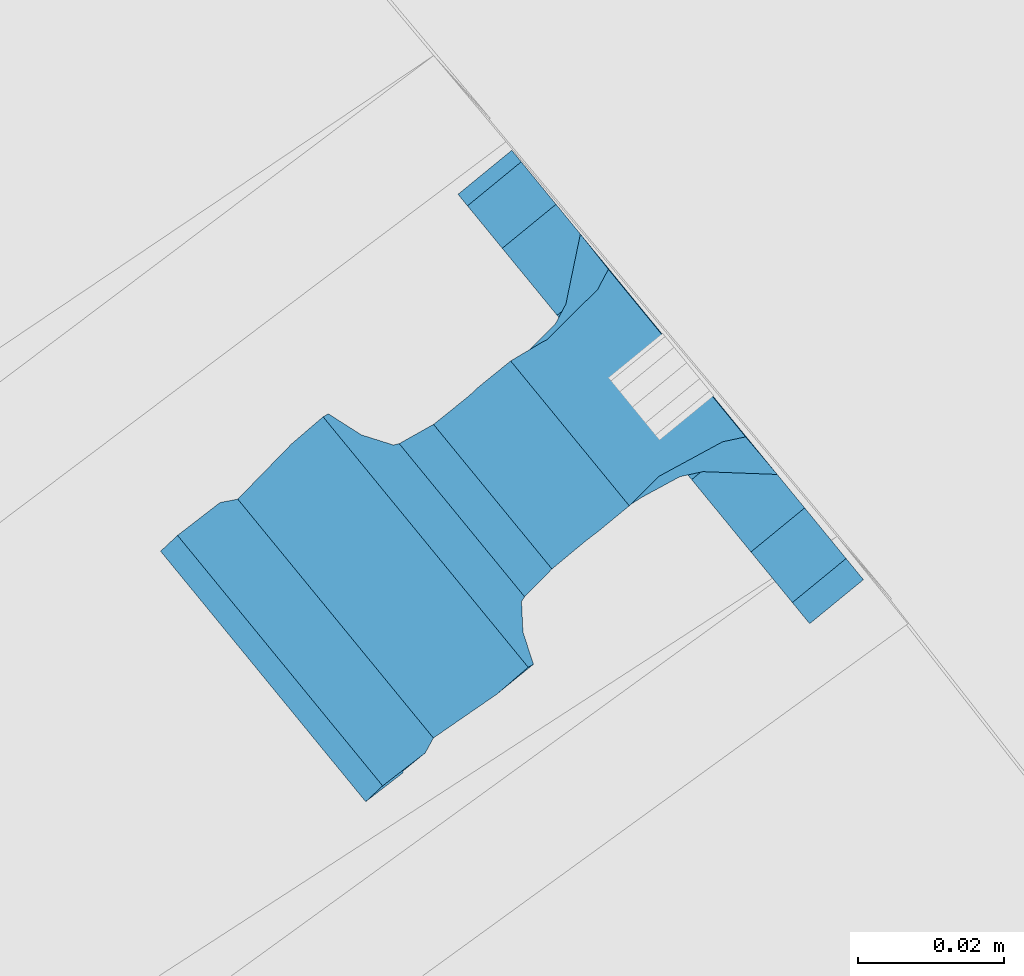
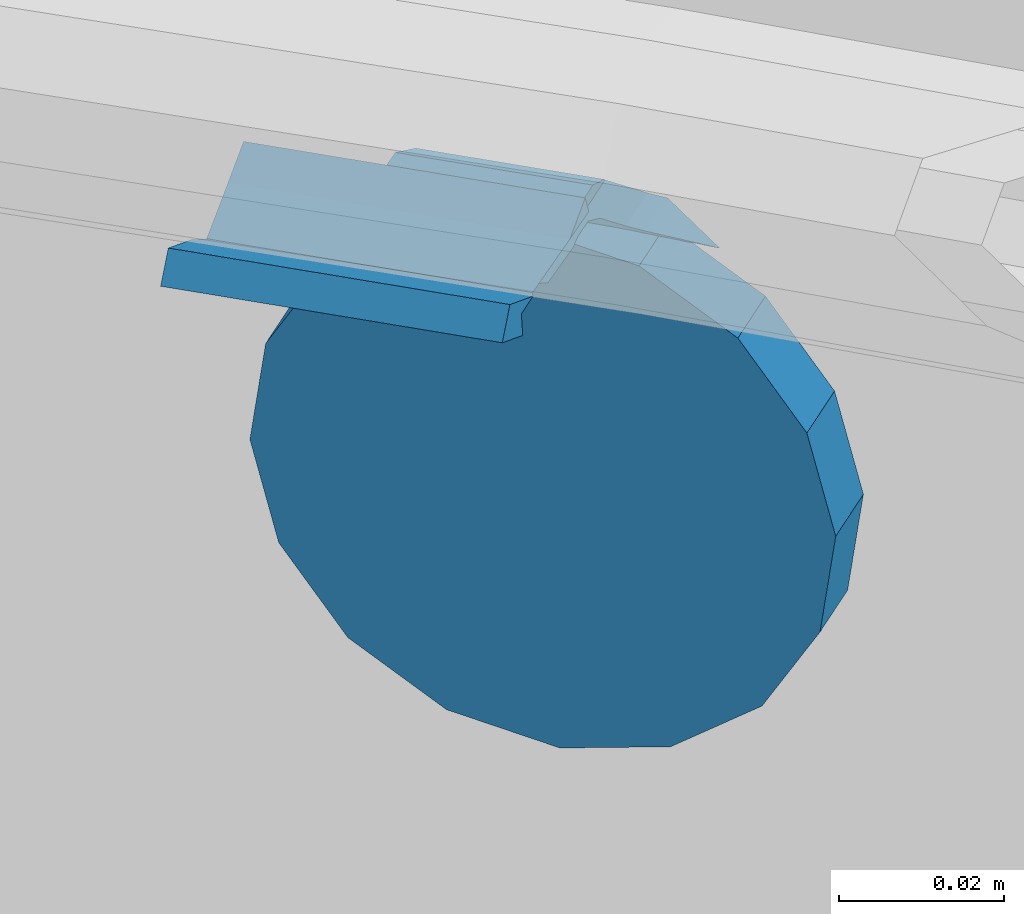
# One storey, part 524 of 975: 1 beam.
"""IFC2X3 building model written with IfcOpenShell, lengths in millimetres."""

import ifcopenshell
import ifcopenshell.guid

model = None  # the IFC model being written
_history = None  # IfcOwnerHistory: only IFC2X3 demands one
_inside = {}  # id of a spatial element -> (the spatial element, [elements in it])
_under = {}  # id of a project, library or spatial element -> (it, [spatial elements below it])
_declared = {}  # id of a project -> (the project, [libraries it declares])
_typed = {}  # id of a type object -> (the type object, [elements of that type])
_made_of = {}  # id of a material, layer set ... -> (it, [elements and type objects made of it])


def new_model(schema):
    """Start an empty IFC model of exactly this schema.

    Asked for "IFC4X3", IfcOpenShell would pick the latest addendum, in which some entities
    have other attributes; the version numbers below select the first issue.
    IFC2X3 requires an IfcOwnerHistory on every rooted entity: one is made here for all.
    """
    global model, _history
    if schema == "IFC4X3":
        model = ifcopenshell.file(schema_version=(4, 3, 0, 0))
    else:
        model = ifcopenshell.file(schema=schema)
    _inside.clear()
    _under.clear()
    _declared.clear()
    _typed.clear()
    _made_of.clear()
    _history = None
    if model.schema == "IFC2X3":
        org = make("IfcOrganization", Name="unknown")
        user = make(
            "IfcPersonAndOrganization",
            ThePerson=make("IfcPerson", FamilyName="unknown"),
            TheOrganization=org,
        )
        app = make(
            "IfcApplication",
            ApplicationDeveloper=org,
            Version="unknown",
            ApplicationFullName="unknown",
            ApplicationIdentifier="unknown",
        )
        _history = make(
            "IfcOwnerHistory",
            OwningUser=user,
            OwningApplication=app,
            ChangeAction="ADDED",
            CreationDate=0,
        )
    return model


def make(cls, **values):
    """One entity of the class cls with the attributes given. An attribute that is None is left unset."""
    return model.create_entity(
        cls, **{name: value for name, value in values.items() if value is not None}
    )


def rooted(cls, **values):
    """An entity with a GlobalId (a new one), such as an element, a storey or a relation."""
    return make(cls, GlobalId=ifcopenshell.guid.new(), OwnerHistory=_history, **values)


def si_unit(unit_type, name, prefix=None):
    """IfcSIUnit, for example si_unit("LENGTHUNIT", "METRE", prefix="MILLI")."""
    return make("IfcSIUnit", UnitType=unit_type, Prefix=prefix, Name=name)


def assignment(units):
    """IfcUnitAssignment: the units of a project."""
    return None if units is None else make("IfcUnitAssignment", Units=units)


def point(xyz):
    """IfcCartesianPoint."""
    return None if xyz is None else make("IfcCartesianPoint", Coordinates=xyz)


def direction(xyz):
    """IfcDirection."""
    return None if xyz is None else make("IfcDirection", DirectionRatios=xyz)


def frame(location, z_axis=None, x_axis=None):
    """IfcAxis2Placement3D, a coordinate frame: its origin and axes. An axis left out is left unset."""
    return make(
        "IfcAxis2Placement3D",
        Location=point(location),
        Axis=direction(z_axis),
        RefDirection=direction(x_axis),
    )


def origin_with_axes():
    """The frame at (0, 0, 0) with the z axis (0, 0, 1) and the x axis (1, 0, 0) written out."""
    return frame((0.0, 0.0, 0.0), z_axis=(0.0, 0.0, 1.0), x_axis=(1.0, 0.0, 0.0))


def place(relative_to, where):
    """IfcLocalPlacement: puts the frame where relative to a parent placement (None: the world)."""
    return make(
        "IfcLocalPlacement", PlacementRelTo=relative_to, RelativePlacement=where
    )


def context(
    kind, dimensions, precision=None, world=None, true_north=None, identifier=None
):
    """IfcGeometricRepresentationContext, for example the 3D "Model" context."""
    return make(
        "IfcGeometricRepresentationContext",
        ContextIdentifier=identifier,
        ContextType=kind,
        CoordinateSpaceDimension=dimensions,
        Precision=precision,
        WorldCoordinateSystem=world,
        TrueNorth=true_north,
    )


def subcontext(parent, identifier, kind, view, scale=None):
    """IfcGeometricRepresentationSubContext, for example "Body" below "Model"."""
    return make(
        "IfcGeometricRepresentationSubContext",
        ContextIdentifier=identifier,
        ContextType=kind,
        ParentContext=parent,
        TargetScale=scale,
        TargetView=view,
    )


def project(units=None, contexts=None):
    """IfcProject with its units and contexts."""
    return rooted(
        "IfcProject",
        Name="project",
        RepresentationContexts=contexts,
        UnitsInContext=assignment(units),
    )


def spatial(cls, under=None, at=None, **own):
    """A site, building, storey or space (cls), placed at a placement, below another one or the project."""
    s = rooted(cls, ObjectPlacement=at, **own)
    if under is not None:
        _under.setdefault(under.id(), (under, []))[1].append(s)
    return s


def faces_of(points, faces, orient=None, outer=None):
    """IfcFace entities. A face is a list of loops; a loop is a list of indices into points, from 0.

    orient and outer hold one flag for each loop. By default every Orientation is true, the
    first loop of a face is its IfcFaceOuterBound and the others are IfcFaceBound.
    """
    made = []
    for i, loops in enumerate(faces):
        bounds = []
        for j, loop in enumerate(loops):
            is_outer = j == 0 if outer is None else outer[i][j]
            bounds.append(
                make(
                    "IfcFaceOuterBound" if is_outer else "IfcFaceBound",
                    Bound=make("IfcPolyLoop", Polygon=[points[k] for k in loop]),
                    Orientation=True if orient is None else orient[i][j],
                )
            )
        made.append(make("IfcFace", Bounds=bounds))
    return made


def faceted_brep(points, faces, orient=None, outer=None, voids=None):
    """IfcFacetedBrep: a solid bounded by flat faces; with voids (closed shells), ...WithVoids."""
    shared = [point(p) for p in points]
    hull = make("IfcClosedShell", CfsFaces=faces_of(shared, faces, orient, outer))
    if voids is None:
        return make("IfcFacetedBrep", Outer=hull)
    return make(
        "IfcFacetedBrepWithVoids",
        Outer=hull,
        Voids=[
            make(cls, CfsFaces=faces_of(shared, fs, o, b)) for cls, fs, o, b in voids
        ],
    )


def shape(context_of_items, identifier, shape_type, items):
    """IfcShapeRepresentation: the items that make up one representation, for example the "Body"."""
    return make(
        "IfcShapeRepresentation",
        ContextOfItems=context_of_items,
        RepresentationIdentifier=identifier,
        RepresentationType=shape_type,
        Items=items,
    )


def material(Name=None, Category=None):
    """IfcMaterial."""
    return make("IfcMaterial", Name=Name, Category=Category)


def made_of(thing, what):
    """Note that an element or type object is made of a material, layer set ...; save() writes the relation."""
    if what is not None:
        _made_of.setdefault(what.id(), (what, []))[1].append(thing)
    return thing


def type_object(cls, material=None, **own):
    """A type object (cls), such as IfcWallType, which elements share."""
    return made_of(rooted(cls, **own), material)


def element(
    cls,
    number,
    at=None,
    inside=None,
    cuts=None,
    type_object=None,
    material=None,
    context=None,
    identifier="Body",
    shape_type=None,
    held_by="IfcProductDefinitionShape",
    body=None,
    shapes=None,
    **own,
):
    """One element of the class cls, such as IfcWall. Its Tag is "e" and its number.

    at: its placement. inside: the storey or other place that contains it. cuts: it is an
    opening in that element (IfcRelVoidsElement). A single representation is given by context,
    identifier, shape_type and body (its items); several are given by shapes. held_by: the class
    of the entity that holds the representations. save() writes the other relations.
    """
    e = rooted(cls, Tag="e%d" % number, ObjectPlacement=at, **own)
    if body is not None:
        shapes = [shape(context, identifier, shape_type, body)]
    if shapes is not None:
        e.Representation = make(held_by, Representations=shapes)
    if inside is not None:
        _inside.setdefault(inside.id(), (inside, []))[1].append(e)
    if cuts is not None:
        rooted(
            "IfcRelVoidsElement", RelatingBuildingElement=cuts, RelatedOpeningElement=e
        )
    if type_object is not None:
        _typed.setdefault(type_object.id(), (type_object, []))[1].append(e)
    return made_of(e, material)


def aggregate(whole, parts):
    """IfcRelAggregates: a whole, such as a stair, and the parts it consists of."""
    return rooted("IfcRelAggregates", RelatingObject=whole, RelatedObjects=parts)


def save(model, path):
    """Write the relations noted so far, then the file.

    IfcRelAggregates (storeys below a building ...), IfcRelContainedInSpatialStructure (elements
    in a storey), IfcRelDefinesByType, IfcRelAssociatesMaterial and IfcRelDeclares: one each for
    every whole, place, type object, material and project.
    """
    for whole, parts in _under.values():
        aggregate(whole, parts)
    for where, things in _inside.values():
        rooted(
            "IfcRelContainedInSpatialStructure",
            RelatedElements=things,
            RelatingStructure=where,
        )
    for kind, things in _typed.values():
        rooted("IfcRelDefinesByType", RelatedObjects=things, RelatingType=kind)
    for what, things in _made_of.values():
        rooted("IfcRelAssociatesMaterial", RelatedObjects=things, RelatingMaterial=what)
    for by, libraries in _declared.values():
        rooted("IfcRelDeclares", RelatingContext=by, RelatedDefinitions=libraries)
    model.write(path)


model = new_model("IFC2X3")

# Units and contexts
model_context = context("Model", 3, precision=1e-05, world=origin_with_axes())
body_context = subcontext(model_context, "Body", "Model", "MODEL_VIEW")
ifc_project = project(units=[si_unit("LENGTHUNIT", "METRE", prefix="MILLI"), si_unit("AREAUNIT", "SQUARE_METRE"), si_unit("VOLUMEUNIT", "CUBIC_METRE"), si_unit("MASSUNIT", "GRAM", prefix="KILO"), si_unit("TIMEUNIT", "SECOND"), si_unit("PLANEANGLEUNIT", "RADIAN"), si_unit("SOLIDANGLEUNIT", "STERADIAN"), si_unit("THERMODYNAMICTEMPERATUREUNIT", "DEGREE_CELSIUS"), si_unit("LUMINOUSINTENSITYUNIT", "LUMEN")], contexts=[model_context])

# Site, building, storey
site_placement = place(None, origin_with_axes())
site = spatial("IfcSite", under=ifc_project, at=site_placement, CompositionType="ELEMENT")
building_placement = place(site_placement, origin_with_axes())
building = spatial("IfcBuilding", under=site, at=building_placement, Name="Undefined", CompositionType="ELEMENT")
storey_placement = place(building_placement, origin_with_axes())
storey = spatial("IfcBuildingStorey", under=building, at=storey_placement, Name="Undefined", CompositionType="ELEMENT", Elevation=0.0)

# Beam
ifc_material = material(Name="STEEL/A36")
beam_type = type_object("IfcBeamType", PredefinedType="NOTDEFINED")
beam_placement = place(storey_placement, frame((38536.1388478404, 6522.06353865258, 1176.83098789018), z_axis=(-0.632522289354666, 0.772347551891617, -0.0582650200082214), x_axis=(0.773661886938144, 0.633598677949465, -2.00000510756914e-09)))
element("IfcBeam", 1, at=beam_placement, inside=storey, type_object=beam_type, material=ifc_material, Name="WALL BRACKET", context=body_context, shape_type="Brep", body=[
    faceted_brep([(1.90771711521666, -39.1274654847043, -0.00448519562360161), (4.12781207483931, -37.3142139539234, 11.6585228966114), (9.52543532932032, -37.3142139512213, 11.6585229003122), (9.43572677535121, -39.1274654809358, -0.00448519046040019), (4.12781622100738, -37.3142113462759, -11.6674928794018), (9.52543536164012, -37.3142113435738, -11.6674928757002), (9.52543536943995, -32.9057339591063, -20.5052188302207), (-59.3625452807173, -69.3784655982474, -22.2294880754935), (-59.3625471014821, -69.3784656013463, 22.22051192456), (-62.5372290253217, -65.8290940115519, 22.2205117947715), (-62.5372272045788, -65.829094008453, -22.2294882052784), (-56.0005462189947, -62.6810153936769, -19.4001536583237), (-56.0005462227564, -65.8290917724489, -22.2294876973629), (-56.0005462202826, -62.681015449916, -22.2294879373212), (-51.9926134504567, -65.8290917755876, -22.2294877733802), (-33.6292472686109, -68.3522709460985, 22.2205129786789), (-32.8097419084297, -65.8290964855291, 22.2205130124285), (-39.3123383228012, -65.979826946405, 22.220512746062), (-33.6292454476352, -68.3522709430574, -22.2294870213718), (-39.3123365018328, -65.9798269432699, -22.2294872539878), (-32.8097385636356, -65.8290917906093, -22.2294869876241), (-49.8277636883067, -64.7864958074726, -21.2924544419693), (-49.8277654249105, -64.7864958104751, 21.1008511326818), (-51.9926250505087, -65.8290964884143, 22.2205122266714), (-56.0001150823664, -62.6808069392628, 22.2205120627459), (-56.0005462074841, -65.8290964708895, 22.0378882089371), (-56.0005462048284, -62.681014627902, 19.2085504620054), (-50.6236011268265, -60.0914679008729, -17.0727975240698), (-50.6236025177132, -60.0914679032776, 16.8811960084004), (-37.4815476433287, -61.5838239838195, -18.41405273702), (-37.4843613082412, -61.5826525936984, 18.2213978637983), (-36.5624089686025, -61.9675237354602, -18.7589029365608), (-36.5624104977469, -61.9675237380143, 18.5673007056721), (-35.6656772816132, -59.2065768799944, -16.277501604779), (-35.6656786073509, -59.2065768823657, 16.0859004289514), (-31.1365753532591, -60.6775902087256, -17.5995750168049), (-34.0664704432347, -56.6444110033883, -13.9747547024399), (-28.6192177466946, -56.6444110076541, -13.9747547049501), (-3.23250514597021, -49.4741793712751, -12.2115825119654), (-26.7500778907925, -49.4741793528585, -12.2115825011288), (-23.8991918155225, -47.8232962113207, -12.5029144205391), (-15.4693896953322, -47.5113669671782, -12.5579606869233), (-13.5254114535564, -47.9195514458443, -12.4859282322896), (-10.0154202657941, -47.8634158650693, -12.4958344996949), (-6.87286303067231, -46.2989595909044, -12.7719146400996), (-0.974046807423292, -41.4811318036436, -13.6221183756297), (6.55396309496427, -41.4811318095387, -13.6221183790976), (-3.86056042498967, -49.9871402948386, -12.3377204786066), (-8.88833529744443, -52.4901126906682, -12.9532056622584), (-14.5039675113076, -52.5799239633861, -12.975290406036), (-16.4479457601483, -52.1717394847385, -12.8749171454001), (-22.5788864578426, -52.3986036117494, -12.9307034198746), (-27.8880959805538, -55.4730458560462, -13.6867140147533), (-31.1991459407436, -52.0505332718412, -12.8451123267887), (-8.88833635080664, -52.4901126925429, 12.7616083185248), (-14.503968566496, -52.5799239652715, 12.7836930424628), (-16.4479468071222, -52.171739486608, 12.6833198734348), (-22.5788875093858, -52.3986036136271, 12.7391060973714), (-27.8880970940227, -55.4730458580361, 13.4951160033006), (-31.1365767873285, -60.6775902112895, 17.4079732795044), (-28.6192207215063, -56.6444139540145, 13.783157155035), (-34.0664734189049, -56.6444139511448, 13.7831571531469), (-31.1991469852655, -52.0505332737077, 12.6535150827658), (-26.7500833238446, -49.4741819259821, 12.0199864668184), (-23.8991928320174, -47.823296213136, 12.3113191992961), (-15.469390716331, -47.5113669690018, 12.3663655323317), (-13.5254124686471, -47.9195514476544, 12.294332988411), (-10.0154212816924, -47.8634158668774, 12.3042392674952), (-6.87286406916974, -46.298959592747, 12.5803197484183), (9.52543537061138, -32.9057339862675, -21.3473800764114), (1.90771935590601, -39.1274641541165, -14.9665223671827), (-0.97405142064963, -41.481134668353, 13.4305240281101), (1.90771428571315, -39.1274673022992, 14.7749285169002), (9.52543531150877, -32.9057326102761, 21.316236062763), (9.52543531263655, -32.9057326367222, 20.496260397289), (9.43572925830813, -39.1274641600116, -14.9665223706525), (6.55395824985317, -41.4811346723191, 13.4305240307158), (-3.23250873251527, -49.4741819383717, 12.0199864749611), (-3.86056142790767, -49.9871402966196, 12.1461236957257), (9.43572374406358, -39.1274673062653, 14.7749285195068), (0.0, -26.940768363208, 26.9407683632162), (-1.09139364212751e-11, -35.1998101886752, 14.5802387730655), (9.52499999988504, -35.1998101886779, 14.5802387731401), (9.52499999999418, -26.9407683632098, 26.940768363238), (1.2732925824821e-11, -14.5802387731151, 35.1998101887366), (9.52500000000691, -14.5802387731169, 35.1998101887584), (0.0, 0.0, 38.0999984741211), (9.52500000001783, -1.13686837721616e-11, 38.1000000001295), (3.27418092638254e-11, 14.5802387730973, 35.1998101888166), (9.5250000000251, 14.580238773096, 35.1998101888312), (3.45607986673713e-11, 26.9407683631939, 26.9407683633472), (9.52500000002692, 26.9407683631925, 26.9407683633617), (3.27418092638254e-11, 35.1998101886679, 14.5802387732328), (9.5250000000251, 35.1998101886661, 14.580238773262), (2.36468622460961e-11, 38.0999999999908, 8.73114913702011e-11), (9.52500000001783, 38.099999999989, 1.23691279441118e-10), (1.45519152283669e-11, 35.1998101886752, -14.5802387730655), (9.52500000000509, 35.1998101886734, -14.5802387730364), (1.81898940354586e-12, 26.9407683632071, -26.9407683632162), (9.52499999999418, 26.9407683632057, -26.9407683631944), (-1.09139364212751e-11, 14.5802387731146, -35.1998101887511), (9.52499999997963, 14.5802387731133, -35.199810188722), (0.0, 0.0, -38.0999984741211), (9.52499999996871, 7.73070496506989e-12, -38.1000000000931), (-2.91038304567337e-11, -14.5802387730978, -35.1998101888239), (9.52499999996326, -14.5802387730996, -35.1998101888021), (-3.27418092638254e-11, -26.9407683631948, -26.9407683633617), (9.52499999995962, -26.9407683631966, -26.9407683633399), (-3.09228198602796e-11, -35.1998101886688, -14.5802387732401), (9.5249999999578, -35.1998101886768, -14.5802387731064), (-2.36468622460961e-11, -38.0999999999917, -9.45874489843845e-11), (9.52499999997235, -38.0999999999935, -7.27595761418343e-11)], [[[0, 1, 2, 3]], [[4, 0, 3, 5]], [[4, 5, 6]], [[7, 8, 9, 10]], [[11, 12, 13]], [[7, 10, 13, 12, 14]], [[15, 16, 17]], [[18, 19, 20]], [[17, 19, 18, 15]], [[21, 19, 17, 22]], [[8, 7, 14, 21, 22, 23]], [[24, 9, 8, 23, 25]], [[24, 25, 26]], [[27, 11, 13, 10, 9, 24, 26, 28]], [[29, 27, 28, 30]], [[31, 29, 30, 32]], [[33, 31, 32, 34]], [[35, 20, 19, 21, 14, 12, 11, 27, 29, 31, 33, 36, 37]], [[38, 39, 40, 41, 42, 43, 44, 45, 46]], [[47, 48, 49, 50, 51, 52, 37, 36, 53, 39, 38]], [[49, 48, 54, 55]], [[50, 49, 55, 56]], [[51, 50, 56, 57]], [[52, 51, 57, 58]], [[59, 35, 37, 52, 58, 60]], [[15, 18, 20, 35, 59, 16]], [[60, 61, 34, 32, 30, 28, 26, 25, 23, 22, 17, 16, 59]], [[53, 36, 33, 34, 61, 62]], [[40, 39, 53, 62, 63, 64]], [[41, 40, 64, 65]], [[42, 41, 65, 66]], [[43, 42, 66, 67]], [[44, 43, 67, 68]], [[1, 0, 4, 6, 69, 70, 45, 44, 68, 71, 72, 73, 74]], [[70, 69, 75]], [[46, 45, 70, 75]], [[76, 77, 78, 47, 38, 46, 75, 79]], [[48, 47, 78, 54]], [[77, 63, 62, 61, 60, 58, 57, 56, 55, 54, 78]], [[76, 71, 68, 67, 66, 65, 64, 63, 77]], [[79, 72, 71, 76]], [[72, 79, 73]], [[75, 69, 6, 5, 3, 2, 74, 73, 79]], [[1, 74, 2]], [[80, 81, 82, 83]], [[84, 80, 83, 85]], [[86, 84, 85, 87]], [[88, 86, 87, 89]], [[90, 88, 89, 91]], [[92, 90, 91, 93]], [[94, 92, 93, 95]], [[96, 94, 95, 97]], [[98, 96, 97, 99]], [[100, 98, 99, 101]], [[102, 100, 101, 103]], [[104, 102, 103, 105]], [[106, 104, 105, 107]], [[108, 106, 107, 109]], [[81, 80, 84, 86, 88, 90, 92, 94, 96, 98, 100, 102, 104, 106, 108, 110]], [[81, 110, 111, 82]], [[107, 105, 103, 101, 99, 97, 95, 93, 91, 89, 87, 85, 83, 82, 111, 109]], [[110, 108, 109, 111]]]),
])

save(model, "model.ifc")
